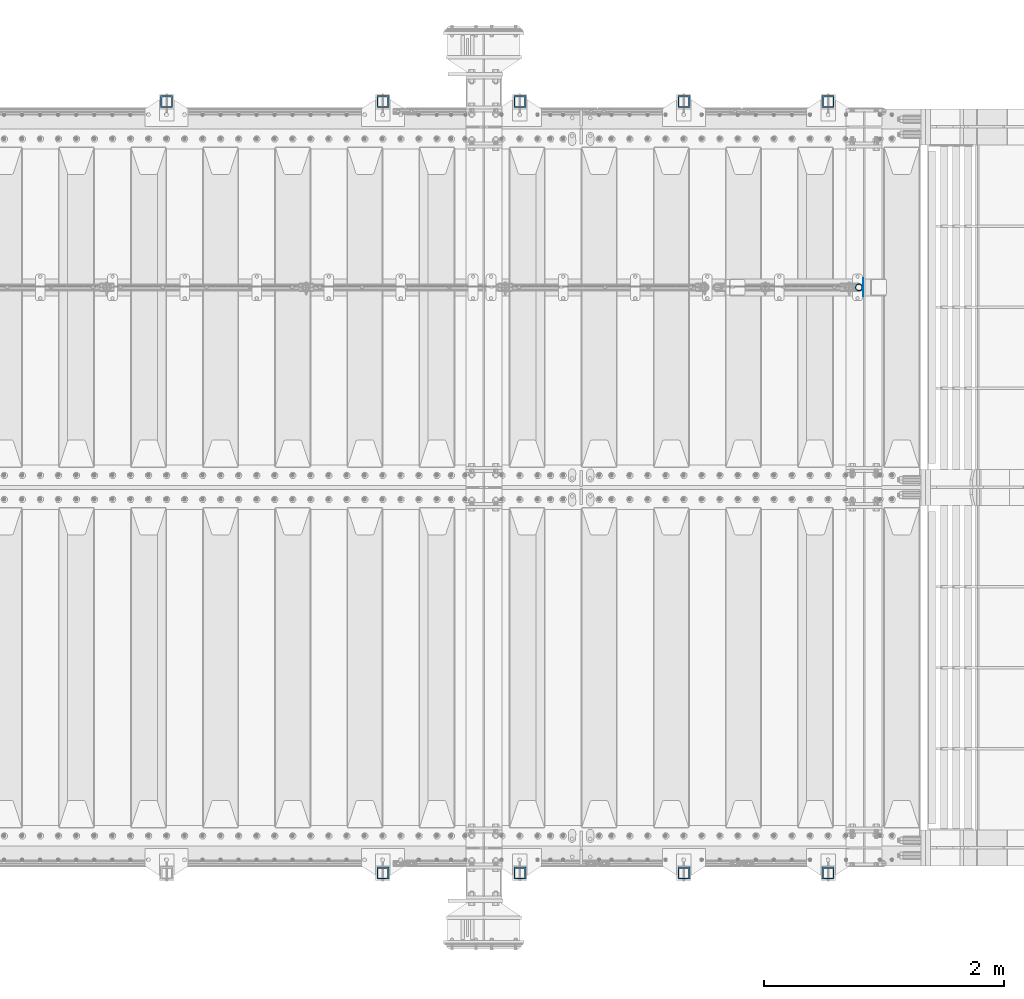
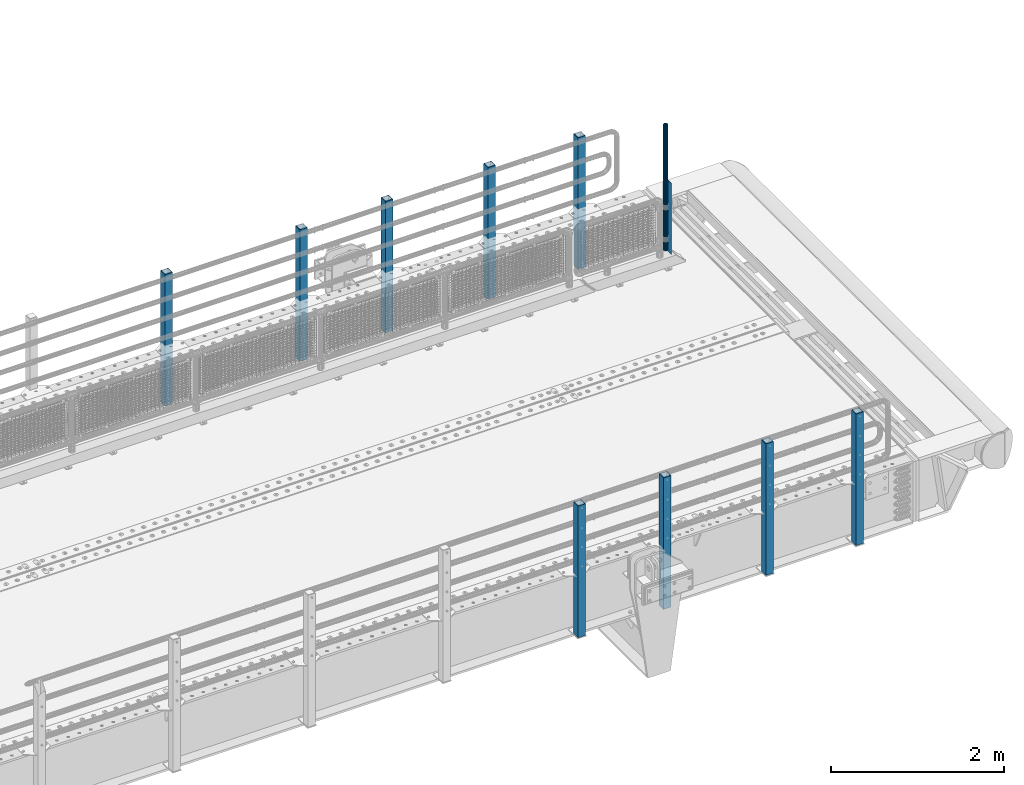
# One storey, part 50 of 193: 11 columns.
"""IFC2X3 building model written with IfcOpenShell, lengths in millimetres."""

import ifcopenshell
import ifcopenshell.guid

model = None  # the IFC model being written
_history = None  # IfcOwnerHistory: only IFC2X3 demands one
_inside = {}  # id of a spatial element -> (the spatial element, [elements in it])
_under = {}  # id of a project, library or spatial element -> (it, [spatial elements below it])
_declared = {}  # id of a project -> (the project, [libraries it declares])
_typed = {}  # id of a type object -> (the type object, [elements of that type])
_made_of = {}  # id of a material, layer set ... -> (it, [elements and type objects made of it])


def new_model(schema):
    """Start an empty IFC model of exactly this schema.

    Asked for "IFC4X3", IfcOpenShell would pick the latest addendum, in which some entities
    have other attributes; the version numbers below select the first issue.
    IFC2X3 requires an IfcOwnerHistory on every rooted entity: one is made here for all.
    """
    global model, _history
    if schema == "IFC4X3":
        model = ifcopenshell.file(schema_version=(4, 3, 0, 0))
    else:
        model = ifcopenshell.file(schema=schema)
    _inside.clear()
    _under.clear()
    _declared.clear()
    _typed.clear()
    _made_of.clear()
    _history = None
    if model.schema == "IFC2X3":
        org = make("IfcOrganization", Name="unknown")
        user = make(
            "IfcPersonAndOrganization",
            ThePerson=make("IfcPerson", FamilyName="unknown"),
            TheOrganization=org,
        )
        app = make(
            "IfcApplication",
            ApplicationDeveloper=org,
            Version="unknown",
            ApplicationFullName="unknown",
            ApplicationIdentifier="unknown",
        )
        _history = make(
            "IfcOwnerHistory",
            OwningUser=user,
            OwningApplication=app,
            ChangeAction="ADDED",
            CreationDate=0,
        )
    return model


def make(cls, **values):
    """One entity of the class cls with the attributes given. An attribute that is None is left unset."""
    return model.create_entity(
        cls, **{name: value for name, value in values.items() if value is not None}
    )


def rooted(cls, **values):
    """An entity with a GlobalId (a new one), such as an element, a storey or a relation."""
    return make(cls, GlobalId=ifcopenshell.guid.new(), OwnerHistory=_history, **values)


def si_unit(unit_type, name, prefix=None):
    """IfcSIUnit, for example si_unit("LENGTHUNIT", "METRE", prefix="MILLI")."""
    return make("IfcSIUnit", UnitType=unit_type, Prefix=prefix, Name=name)


def assignment(units):
    """IfcUnitAssignment: the units of a project."""
    return None if units is None else make("IfcUnitAssignment", Units=units)


def point(xyz):
    """IfcCartesianPoint."""
    return None if xyz is None else make("IfcCartesianPoint", Coordinates=xyz)


def direction(xyz):
    """IfcDirection."""
    return None if xyz is None else make("IfcDirection", DirectionRatios=xyz)


def frame(location, z_axis=None, x_axis=None):
    """IfcAxis2Placement3D, a coordinate frame: its origin and axes. An axis left out is left unset."""
    return make(
        "IfcAxis2Placement3D",
        Location=point(location),
        Axis=direction(z_axis),
        RefDirection=direction(x_axis),
    )


def origin_with_axes():
    """The frame at (0, 0, 0) with the z axis (0, 0, 1) and the x axis (1, 0, 0) written out."""
    return frame((0.0, 0.0, 0.0), z_axis=(0.0, 0.0, 1.0), x_axis=(1.0, 0.0, 0.0))


def place(relative_to, where):
    """IfcLocalPlacement: puts the frame where relative to a parent placement (None: the world)."""
    return make(
        "IfcLocalPlacement", PlacementRelTo=relative_to, RelativePlacement=where
    )


def context(
    kind, dimensions, precision=None, world=None, true_north=None, identifier=None
):
    """IfcGeometricRepresentationContext, for example the 3D "Model" context."""
    return make(
        "IfcGeometricRepresentationContext",
        ContextIdentifier=identifier,
        ContextType=kind,
        CoordinateSpaceDimension=dimensions,
        Precision=precision,
        WorldCoordinateSystem=world,
        TrueNorth=true_north,
    )


def subcontext(parent, identifier, kind, view, scale=None):
    """IfcGeometricRepresentationSubContext, for example "Body" below "Model"."""
    return make(
        "IfcGeometricRepresentationSubContext",
        ContextIdentifier=identifier,
        ContextType=kind,
        ParentContext=parent,
        TargetScale=scale,
        TargetView=view,
    )


def project(units=None, contexts=None):
    """IfcProject with its units and contexts."""
    return rooted(
        "IfcProject",
        Name="project",
        RepresentationContexts=contexts,
        UnitsInContext=assignment(units),
    )


def spatial(cls, under=None, at=None, **own):
    """A site, building, storey or space (cls), placed at a placement, below another one or the project."""
    s = rooted(cls, ObjectPlacement=at, **own)
    if under is not None:
        _under.setdefault(under.id(), (under, []))[1].append(s)
    return s


def faces_of(points, faces, orient=None, outer=None):
    """IfcFace entities. A face is a list of loops; a loop is a list of indices into points, from 0.

    orient and outer hold one flag for each loop. By default every Orientation is true, the
    first loop of a face is its IfcFaceOuterBound and the others are IfcFaceBound.
    """
    made = []
    for i, loops in enumerate(faces):
        bounds = []
        for j, loop in enumerate(loops):
            is_outer = j == 0 if outer is None else outer[i][j]
            bounds.append(
                make(
                    "IfcFaceOuterBound" if is_outer else "IfcFaceBound",
                    Bound=make("IfcPolyLoop", Polygon=[points[k] for k in loop]),
                    Orientation=True if orient is None else orient[i][j],
                )
            )
        made.append(make("IfcFace", Bounds=bounds))
    return made


def faceted_brep(points, faces, orient=None, outer=None, voids=None):
    """IfcFacetedBrep: a solid bounded by flat faces; with voids (closed shells), ...WithVoids."""
    shared = [point(p) for p in points]
    hull = make("IfcClosedShell", CfsFaces=faces_of(shared, faces, orient, outer))
    if voids is None:
        return make("IfcFacetedBrep", Outer=hull)
    return make(
        "IfcFacetedBrepWithVoids",
        Outer=hull,
        Voids=[
            make(cls, CfsFaces=faces_of(shared, fs, o, b)) for cls, fs, o, b in voids
        ],
    )


def shape(context_of_items, identifier, shape_type, items):
    """IfcShapeRepresentation: the items that make up one representation, for example the "Body"."""
    return make(
        "IfcShapeRepresentation",
        ContextOfItems=context_of_items,
        RepresentationIdentifier=identifier,
        RepresentationType=shape_type,
        Items=items,
    )


def material(Name=None, Category=None):
    """IfcMaterial."""
    return make("IfcMaterial", Name=Name, Category=Category)


def made_of(thing, what):
    """Note that an element or type object is made of a material, layer set ...; save() writes the relation."""
    if what is not None:
        _made_of.setdefault(what.id(), (what, []))[1].append(thing)
    return thing


def type_object(cls, material=None, **own):
    """A type object (cls), such as IfcWallType, which elements share."""
    return made_of(rooted(cls, **own), material)


def element(
    cls,
    number,
    at=None,
    inside=None,
    cuts=None,
    type_object=None,
    material=None,
    context=None,
    identifier="Body",
    shape_type=None,
    held_by="IfcProductDefinitionShape",
    body=None,
    shapes=None,
    **own,
):
    """One element of the class cls, such as IfcWall. Its Tag is "e" and its number.

    at: its placement. inside: the storey or other place that contains it. cuts: it is an
    opening in that element (IfcRelVoidsElement). A single representation is given by context,
    identifier, shape_type and body (its items); several are given by shapes. held_by: the class
    of the entity that holds the representations. save() writes the other relations.
    """
    e = rooted(cls, Tag="e%d" % number, ObjectPlacement=at, **own)
    if body is not None:
        shapes = [shape(context, identifier, shape_type, body)]
    if shapes is not None:
        e.Representation = make(held_by, Representations=shapes)
    if inside is not None:
        _inside.setdefault(inside.id(), (inside, []))[1].append(e)
    if cuts is not None:
        rooted(
            "IfcRelVoidsElement", RelatingBuildingElement=cuts, RelatedOpeningElement=e
        )
    if type_object is not None:
        _typed.setdefault(type_object.id(), (type_object, []))[1].append(e)
    return made_of(e, material)


def aggregate(whole, parts):
    """IfcRelAggregates: a whole, such as a stair, and the parts it consists of."""
    return rooted("IfcRelAggregates", RelatingObject=whole, RelatedObjects=parts)


def save(model, path):
    """Write the relations noted so far, then the file.

    IfcRelAggregates (storeys below a building ...), IfcRelContainedInSpatialStructure (elements
    in a storey), IfcRelDefinesByType, IfcRelAssociatesMaterial and IfcRelDeclares: one each for
    every whole, place, type object, material and project.
    """
    for whole, parts in _under.values():
        aggregate(whole, parts)
    for where, things in _inside.values():
        rooted(
            "IfcRelContainedInSpatialStructure",
            RelatedElements=things,
            RelatingStructure=where,
        )
    for kind, things in _typed.values():
        rooted("IfcRelDefinesByType", RelatedObjects=things, RelatingType=kind)
    for what, things in _made_of.values():
        rooted("IfcRelAssociatesMaterial", RelatedObjects=things, RelatingMaterial=what)
    for by, libraries in _declared.values():
        rooted("IfcRelDeclares", RelatingContext=by, RelatedDefinitions=libraries)
    model.write(path)


model = new_model("IFC2X3")

# Units and contexts
model_context = context("Model", 3, precision=1e-05, world=origin_with_axes())
body_context = subcontext(model_context, "Body", "Model", "MODEL_VIEW")
ifc_project = project(units=[si_unit("LENGTHUNIT", "METRE", prefix="MILLI"), si_unit("AREAUNIT", "SQUARE_METRE"), si_unit("VOLUMEUNIT", "CUBIC_METRE"), si_unit("MASSUNIT", "GRAM", prefix="KILO"), si_unit("TIMEUNIT", "SECOND"), si_unit("PLANEANGLEUNIT", "RADIAN"), si_unit("SOLIDANGLEUNIT", "STERADIAN"), si_unit("THERMODYNAMICTEMPERATUREUNIT", "DEGREE_CELSIUS"), si_unit("LUMINOUSINTENSITYUNIT", "LUMEN")], contexts=[model_context])

# Site, building, storey
site_placement = place(None, origin_with_axes())
site = spatial("IfcSite", under=ifc_project, at=site_placement, CompositionType="ELEMENT")
building_placement = place(site_placement, origin_with_axes())
building = spatial("IfcBuilding", under=site, at=building_placement, Name="Standard", CompositionType="ELEMENT")
storey_placement = place(building_placement, origin_with_axes())
storey = spatial("IfcBuildingStorey", under=building, at=storey_placement, Name="Undefined", CompositionType="ELEMENT", Elevation=0.0)

# Columns
ifc_material_1 = material(Name="Misc_Undefined")
column_type_1 = type_object("IfcColumnType", PredefinedType="NOTDEFINED")
column_1_placement = place(storey_placement, frame((-28939.0, 28664.5, 238.02), z_axis=(-1.0, 0.0, 0.0), x_axis=(0.0, 0.0, 1.0)))
element("IfcColumn", 1, at=column_1_placement, inside=storey, type_object=column_type_1, material=ifc_material_1, context=body_context, shape_type="Brep", body=[
    faceted_brep([(0.0, -25.3499999999985, 0.0), (0.0, -23.4203461491597, 9.70102501045403), (1761.98, -23.4203461491597, 9.70102501045403), (1761.98, -25.3499999999985, 0.0), (0.0, -17.9251569030785, 17.9251569030785), (1761.98, -17.9251569030785, 17.9251569030785), (0.0, -9.70102501045403, 23.4203461491597), (1761.98, -9.70102501045403, 23.4203461491597), (0.0, 0.0, 25.3499999999985), (1761.98, 0.0, 25.3499999999985), (0.0, 9.70102501045403, 23.4203461491597), (1761.98, 9.70102501045403, 23.4203461491597), (0.0, 17.9251569030785, 17.9251569030785), (1761.98, 17.9251569030785, 17.9251569030785), (0.0, 23.4203461491597, 9.70102501045403), (1761.98, 23.4203461491597, 9.70102501045403), (0.0, 25.3499999999985, 0.0), (1761.98, 25.3499999999985, 0.0), (0.0, 23.4203461491597, -9.70102501045403), (1761.98, 23.4203461491597, -9.70102501045403), (0.0, 17.9251569030785, -17.9251569030785), (1761.98, 17.9251569030785, -17.9251569030785), (0.0, 9.70102501045403, -23.4203461491597), (1761.98, 9.70102501045403, -23.4203461491597), (0.0, 0.0, -25.3499999999985), (1761.98, 0.0, -25.3499999999985), (0.0, -9.70102501045403, -23.4203461491597), (1761.98, -9.70102501045403, -23.4203461491597), (0.0, -17.9251569030785, -17.9251569030785), (1761.98, -17.9251569030785, -17.9251569030785), (0.0, -23.4203461491597, -9.70102501045403), (1761.98, -23.4203461491597, -9.70102501045403), (0.0, -30.1500000000015, 0.0), (0.0, -27.8549679052157, -11.5379054858058), (1761.98, -27.8549679052157, -11.5379054858058), (1761.98, -30.1500000000015, 0.0), (0.0, -21.3192694527752, -21.3192694527752), (1761.98, -21.3192694527752, -21.3192694527752), (0.0, -11.5379054858058, -27.8549679052157), (1761.98, -11.5379054858058, -27.8549679052157), (0.0, 0.0, -30.1500000000015), (1761.98, 0.0, -30.1500000000015), (0.0, 11.5379054858058, -27.8549679052157), (1761.98, 11.5379054858058, -27.8549679052157), (0.0, 21.3192694527752, -21.3192694527752), (1761.98, 21.3192694527752, -21.3192694527752), (0.0, 27.8549679052157, -11.5379054858058), (1761.98, 27.8549679052157, -11.5379054858058), (0.0, 30.1500000000015, 0.0), (1761.98, 30.1500000000015, 0.0), (0.0, 27.8549679052157, 11.5379054858058), (1761.98, 27.8549679052157, 11.5379054858058), (0.0, 21.3192694527752, 21.3192694527752), (1761.98, 21.3192694527752, 21.3192694527752), (0.0, 11.5379054858058, 27.8549679052157), (1761.98, 11.5379054858058, 27.8549679052157), (0.0, 0.0, 30.1500000000015), (1761.98, 0.0, 30.1500000000015), (0.0, -11.5379054858058, 27.8549679052157), (1761.98, -11.5379054858058, 27.8549679052157), (0.0, -21.3192694527752, 21.3192694527752), (1761.98, -21.3192694527752, 21.3192694527752), (0.0, -27.8549679052157, 11.5379054858058), (1761.98, -27.8549679052157, 11.5379054858058)], [[[0, 1, 2, 3]], [[1, 4, 5, 2]], [[4, 6, 7, 5]], [[6, 8, 9, 7]], [[8, 10, 11, 9]], [[10, 12, 13, 11]], [[12, 14, 15, 13]], [[14, 16, 17, 15]], [[16, 18, 19, 17]], [[18, 20, 21, 19]], [[20, 22, 23, 21]], [[22, 24, 25, 23]], [[24, 26, 27, 25]], [[26, 28, 29, 27]], [[28, 30, 31, 29]], [[30, 0, 3, 31]], [[32, 33, 34, 35]], [[33, 36, 37, 34]], [[36, 38, 39, 37]], [[38, 40, 41, 39]], [[40, 42, 43, 41]], [[42, 44, 45, 43]], [[44, 46, 47, 45]], [[46, 48, 49, 47]], [[48, 50, 51, 49]], [[50, 52, 53, 51]], [[52, 54, 55, 53]], [[54, 56, 57, 55]], [[56, 58, 59, 57]], [[58, 60, 61, 59]], [[60, 62, 63, 61]], [[62, 32, 35, 63]], [[37, 39, 41, 43, 45, 47, 49, 51, 53, 55, 57, 59, 61, 63, 35, 34], [5, 7, 9, 11, 13, 15, 17, 19, 21, 23, 25, 27, 29, 31, 3, 2]], [[62, 60, 58, 56, 54, 52, 50, 48, 46, 44, 42, 40, 38, 36, 33, 32], [30, 28, 26, 24, 22, 20, 18, 16, 14, 12, 10, 8, 6, 4, 1, 0]]]),
])
ifc_material_2 = material()
column_type_2 = type_object("IfcColumnType", PredefinedType="NOTDEFINED")
for number, where, z_axis, x_axis in (
    (2, (-29194.9999999999, 30210.0000000002, -844.999999999998), (0.0, -1.0, 0.0), (0.0, 0.0, 1.0)),
    (3, (-30394.9999999999, 30210.0000000002, -844.999999999998), (0.0, -1.0, 0.0), (0.0, 0.0, 1.0)),
    (4, (-31759.9999999999, 30210.0000000002, -844.999999999998), (0.0, -1.0, 0.0), (0.0, 0.0, 1.0)),
    (5, (-32899.9999999999, 30210.0000000002, -844.999999999998), (0.0, -1.0, 0.0), (0.0, 0.0, 1.0)),
    (6, (-34699.9999999999, 30210.0000000002, -844.999999999998), (0.0, -1.0, 0.0), (0.0, 0.0, 1.0)),
    (7, (-29195.0000000001, 23789.9999999998, -844.999999999998), (0.0, 1.0, 0.0), (0.0, 0.0, 1.0)),
    (8, (-30395.0000000001, 23789.9999999998, -844.999999999998), (0.0, 1.0, 0.0), (0.0, 0.0, 1.0)),
    (9, (-31760.0000000001, 23789.9999999998, -844.999999999998), (0.0, 1.0, 0.0), (0.0, 0.0, 1.0)),
    (10, (-32900.0000000001, 23789.9999999998, -844.999999999998), (0.0, 1.0, 0.0), (0.0, 0.0, 1.0)),
):
    element("IfcColumn", number, at=place(storey_placement, frame(where, z_axis=z_axis, x_axis=x_axis)), inside=storey, type_object=column_type_2, material=ifc_material_2, context=body_context, shape_type="Brep", body=[
        faceted_brep([(0.0, 40.0, -40.0), (0.0, -40.0, -40.0), (1855.0, -40.0, -40.0), (1855.0, 40.0, -40.0), (0.0, -40.0, 40.0), (1855.0, -40.0, 40.0), (0.0, 40.0, 40.0), (1855.0, 40.0, 40.0), (0.0, 50.0, -50.0), (0.0, 50.0, 50.0), (1855.0, 50.0, 50.0), (1855.0, 50.0, -50.0), (0.0, -50.0, 50.0), (1855.0, -50.0, 50.0), (0.0, -50.0, -50.0), (1855.0, -50.0, -50.0)], [[[0, 1, 2, 3]], [[1, 4, 5, 2]], [[4, 6, 7, 5]], [[6, 0, 3, 7]], [[8, 9, 10, 11]], [[9, 12, 13, 10]], [[12, 14, 15, 13]], [[14, 8, 11, 15]], [[13, 15, 11, 10], [5, 7, 3, 2]], [[14, 12, 9, 8], [6, 4, 1, 0]]]),
    ])
column_type_3 = type_object("IfcColumnType", PredefinedType="NOTDEFINED")
column_2_placement = place(storey_placement, frame((-28902.5, 28664.5, 200.0), z_axis=(0.0, 1.0, 0.0), x_axis=(0.0, 0.0, 1.0)))
element("IfcColumn", 11, at=column_2_placement, inside=storey, type_object=column_type_3, material=ifc_material_1, context=body_context, shape_type="Brep", body=[
    faceted_brep([(0.0, 1.5, -75.0), (0.0, 1.5, 75.0), (1000.0, 1.5, 75.0), (1000.0, 1.5, -75.0), (0.0, -1.5, 75.0), (1000.0, -1.5, 75.0), (0.0, -1.5, -75.0), (1000.0, -1.5, -75.0)], [[[0, 1, 2, 3]], [[1, 4, 5, 2]], [[4, 6, 7, 5]], [[6, 0, 3, 7]], [[5, 7, 3, 2]], [[6, 4, 1, 0]]]),
])

save(model, "model.ifc")
